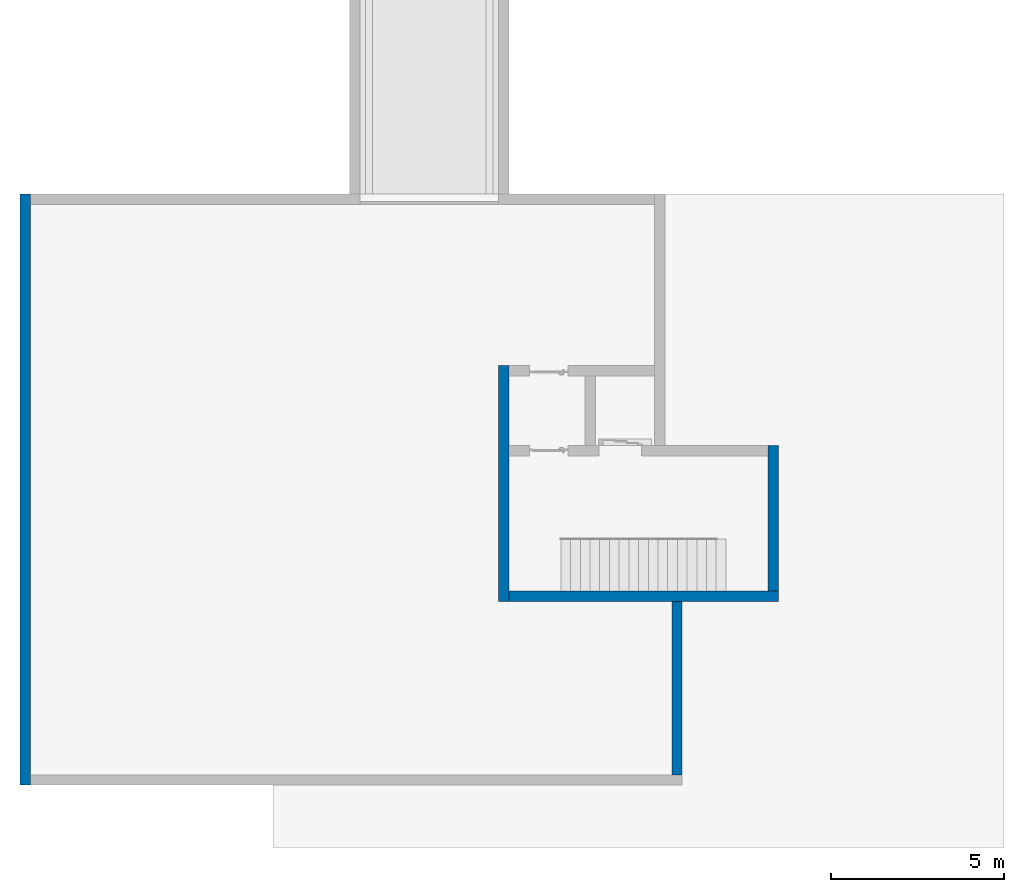
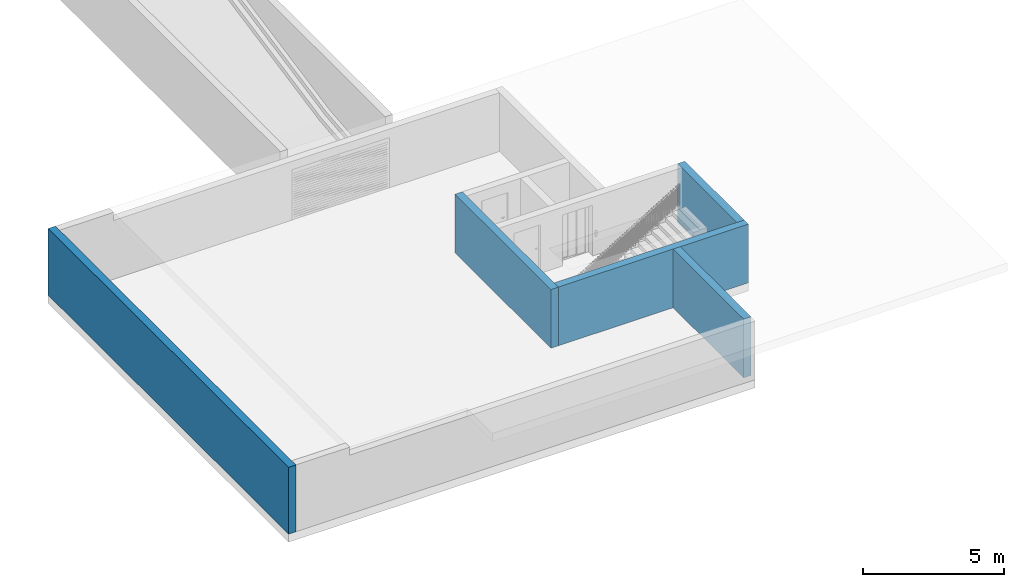
# One storey, part 2 of 6: 5 walls.
"""IFC4 building model written with IfcOpenShell, lengths in metres."""

from ifc_helpers import new_model, entity, si_unit, converted_unit, derived_unit, direction, frame, origin_with_axes, place, context, subcontext, project, spatial, polygons, material, type_object, element, save


model = new_model("IFC4")

# Units and contexts
model_context = context("Model", 3, precision=1e-05, world=origin_with_axes(), true_north=direction((0.0, 1.0)))
body_context = subcontext(model_context, "Body", "Model", "MODEL_VIEW")
ifc_project = project(units=[si_unit("LENGTHUNIT", "METRE"), si_unit("AREAUNIT", "SQUARE_METRE"), si_unit("VOLUMEUNIT", "CUBIC_METRE"), converted_unit("PLANEANGLEUNIT", "DEGREE", entity("IfcPlaneAngleMeasure", 0.0174532925199), si_unit("PLANEANGLEUNIT", "RADIAN"), dimensions=[0, 0, 0, 0, 0, 0, 0]), converted_unit("TIMEUNIT", "Year", entity("IfcTimeMeasure", 31556926.0), si_unit("TIMEUNIT", "SECOND"), dimensions=[0, 0, 1, 0, 0, 0, 0]), si_unit("MASSUNIT", "GRAM", prefix="KILO"), si_unit("THERMODYNAMICTEMPERATUREUNIT", "DEGREE_CELSIUS"), si_unit("LUMINOUSINTENSITYUNIT", "LUMEN"), si_unit("ENERGYUNIT", "JOULE", prefix="MEGA"), derived_unit("THERMALCONDUCTANCEUNIT", [(si_unit("POWERUNIT", "WATT"), 1), (si_unit("LENGTHUNIT", "METRE"), -1), (si_unit("THERMODYNAMICTEMPERATUREUNIT", "KELVIN"), -1)]), derived_unit("SPECIFICHEATCAPACITYUNIT", [(si_unit("ENERGYUNIT", "JOULE"), 1), (si_unit("MASSUNIT", "GRAM", prefix="KILO"), -1), (si_unit("THERMODYNAMICTEMPERATUREUNIT", "KELVIN"), -1)]), derived_unit("MASSDENSITYUNIT", [(si_unit("MASSUNIT", "GRAM", prefix="KILO"), 1), (si_unit("VOLUMEUNIT", "CUBIC_METRE"), -1)])], contexts=[model_context])

# Site, building, storey
site_placement = place(None, origin_with_axes())
site = spatial("IfcSite", under=ifc_project, at=site_placement, CompositionType="ELEMENT")
building_placement = place(site_placement, origin_with_axes())
building = spatial("IfcBuilding", under=site, at=building_placement, CompositionType="ELEMENT")
storey_placement = place(building_placement, frame((0.0, 0.0, -2.89), z_axis=(0.0, 0.0, 1.0), x_axis=(1.0, 0.0, 0.0)))
storey = spatial("IfcBuildingStorey", under=building, at=storey_placement, Name="-1. Geschoss", CompositionType="ELEMENT", Elevation=-2.89)

# Walls
ifc_material = material()
wall_type = type_object("IfcWallType", Name="300", PredefinedType="NOTDEFINED")
wall_1_placement = place(storey_placement, frame((-5.2421993804, -2.52881223104, 0.0), z_axis=(0.0, 0.0, 1.0), x_axis=(0.0, 1.0, 0.0)))
element("IfcWall", 1, at=wall_1_placement, inside=storey, type_object=wall_type, material=ifc_material, Name="Wand-001", PredefinedType="NOTDEFINED", context=body_context, shape_type="Tessellation", body=[
    polygons([(6.5, 0.0, 0.0), (6.5, 0.0, 2.54), (6.5, -0.3, 2.54), (6.5, -0.3, 0.0), (-0.3, 0.0, 0.0), (-0.3, 0.0, 2.54), (-0.3, -0.3, 2.54), (-0.3, -0.3, 0.0)], [[[1, 2, 3, 4]], [[5, 6, 2, 1]], [[6, 7, 3, 2]], [[4, 3, 7, 8]], [[5, 1, 4, 8]], [[8, 7, 6, 5]]], closed=True),
])
wall_2_placement = place(storey_placement, frame((2.8378006196, -2.52881223104, 0.0), z_axis=(0.0, 0.0, 1.0), x_axis=(-1.0, 0.0, 0.0)))
element("IfcWall", 2, at=wall_2_placement, inside=storey, type_object=wall_type, material=ifc_material, Name="Wand-001", PredefinedType="NOTDEFINED", context=body_context, shape_type="Tessellation", body=[
    polygons([(7.78, 0.0, 2.54), (7.12, 0.0, 2.54), (1.8, 0.0, 2.54), (0.0, 0.0, 2.54), (0.0, 0.0, 0.0), (7.78, 0.0, 0.0), (7.78, 0.3, 2.54), (0.0, 0.3, 2.54), (0.0, 0.3, 0.0), (7.78, 0.3, 0.0)], [[[1, 2, 3, 4, 5, 6]], [[4, 3, 2, 1, 7, 8]], [[5, 4, 8, 9]], [[9, 10, 6, 5]], [[10, 7, 1, 6]], [[8, 7, 10, 9]]], closed=True),
])
wall_3_placement = place(storey_placement, frame((2.8378006196, -2.52881223104, 0.0), z_axis=(0.0, 0.0, 1.0), x_axis=(0.0, 1.0, 0.0)))
element("IfcWall", 3, at=wall_3_placement, inside=storey, type_object=wall_type, material=ifc_material, Name="Wand-001", PredefinedType="NOTDEFINED", context=body_context, shape_type="Tessellation", body=[
    polygons([(4.2, 0.3, 0.0), (4.2, 0.3, 2.54), (4.2, 0.0, 2.54), (4.2, 0.0, 0.0), (0.0, 0.3, 0.0), (0.0, 0.3, 2.54), (0.0, 0.0, 2.54), (0.0, 0.0, 0.0)], [[[1, 2, 3, 4]], [[5, 6, 2, 1]], [[6, 7, 3, 2]], [[4, 3, 7, 8]], [[5, 1, 4, 8]], [[8, 7, 6, 5]]], closed=True),
])
wall_4_placement = place(storey_placement, frame((-19.0421993804, -8.12881223104, 0.0), z_axis=(0.0, 0.0, 1.0), x_axis=(0.0, 1.0, 0.0)))
element("IfcWall", 4, at=wall_4_placement, inside=storey, type_object=wall_type, material=ifc_material, Name="Wand-001", PredefinedType="NOTDEFINED", context=body_context, shape_type="Tessellation", body=[
    polygons([(17.05, -0.3, 2.89), (17.05, 0.0, 2.89), (0.0, 0.0, 2.89), (0.0, -0.3, 2.89), (17.05, -0.3, 0.0), (17.05, 0.0, 0.0), (0.0, 0.0, 0.0), (0.0, -0.3, 0.0)], [[[1, 2, 3, 4]], [[2, 1, 5, 6]], [[2, 6, 7, 3]], [[8, 4, 3, 7]], [[5, 1, 4, 8]], [[6, 5, 8, 7]]], closed=True),
])
wall_5_placement = place(storey_placement, frame((-0.0921993803965, -2.52881223104, 0.0), z_axis=(0.0, 0.0, 1.0), x_axis=(0.0, -1.0, 0.0)))
element("IfcWall", 5, at=wall_5_placement, inside=storey, type_object=wall_type, material=ifc_material, Name="Wand-001", PredefinedType="NOTDEFINED", context=body_context, shape_type="Tessellation", body=[
    polygons([(0.3, -0.15, 0.0), (0.3, -0.15, 2.54), (0.3, 0.15, 2.54), (0.3, 0.15, 0.0), (5.3, -0.15, 0.0), (5.3, -0.15, 2.54), (5.3, 0.15, 2.54), (5.3, 0.15, 0.0)], [[[1, 2, 3, 4]], [[5, 6, 2, 1]], [[6, 7, 3, 2]], [[4, 3, 7, 8]], [[4, 8, 5, 1]], [[8, 7, 6, 5]]], closed=True),
])

save(model, "model.ifc")
